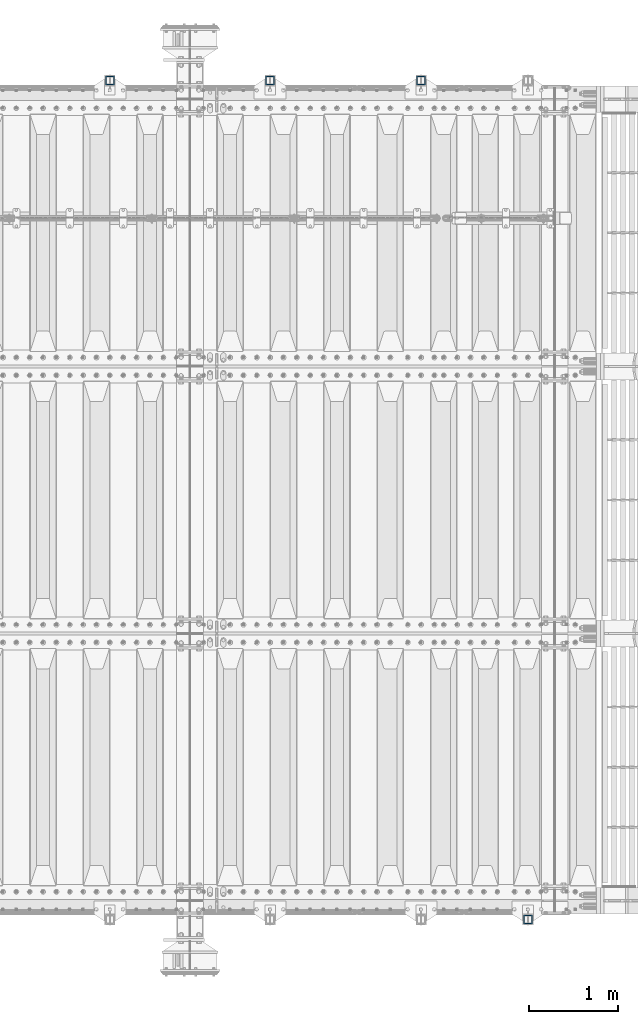
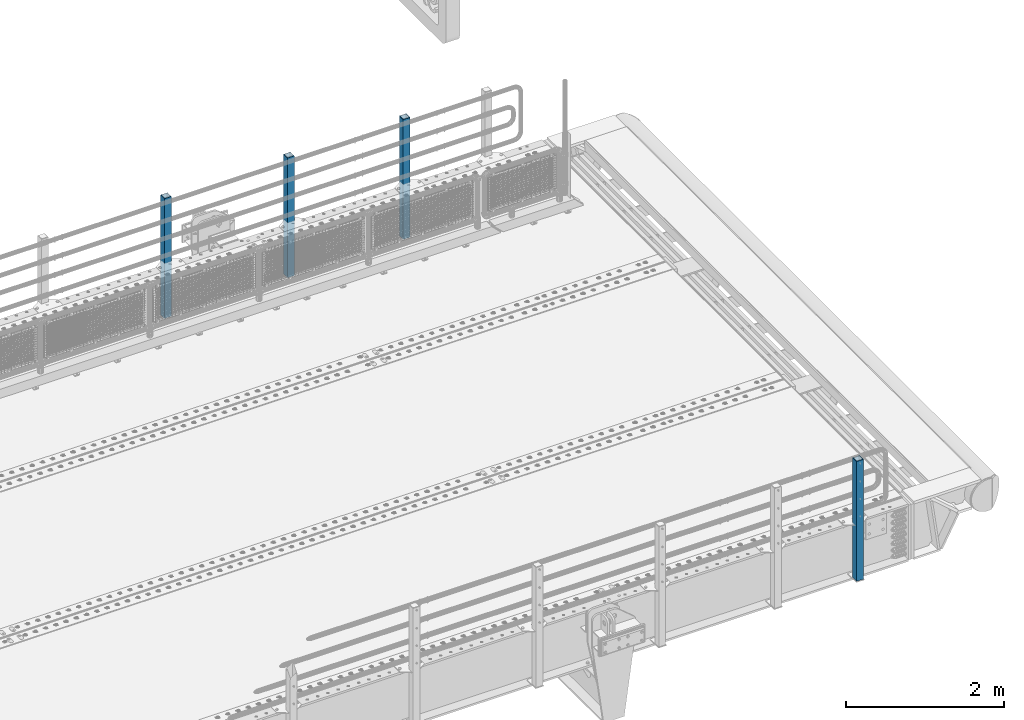
# One storey, part 64 of 247: 4 columns.
"""IFC2X3 building model written with IfcOpenShell, lengths in millimetres."""

from ifc_helpers import new_model, si_unit, frame, origin_with_axes, place, context, subcontext, project, spatial, faceted_brep, material, type_object, element, save


model = new_model("IFC2X3")

# Units and contexts
model_context = context("Model", 3, precision=1e-05, world=origin_with_axes())
body_context = subcontext(model_context, "Body", "Model", "MODEL_VIEW")
ifc_project = project(units=[si_unit("LENGTHUNIT", "METRE", prefix="MILLI"), si_unit("AREAUNIT", "SQUARE_METRE"), si_unit("VOLUMEUNIT", "CUBIC_METRE"), si_unit("MASSUNIT", "GRAM", prefix="KILO"), si_unit("TIMEUNIT", "SECOND"), si_unit("PLANEANGLEUNIT", "RADIAN"), si_unit("SOLIDANGLEUNIT", "STERADIAN"), si_unit("THERMODYNAMICTEMPERATUREUNIT", "DEGREE_CELSIUS"), si_unit("LUMINOUSINTENSITYUNIT", "LUMEN")], contexts=[model_context])

# Site, building, storey
site_placement = place(None, origin_with_axes())
site = spatial("IfcSite", under=ifc_project, at=site_placement, CompositionType="ELEMENT")
building_placement = place(site_placement, origin_with_axes())
building = spatial("IfcBuilding", under=site, at=building_placement, Name="Standard", CompositionType="ELEMENT")
storey_placement = place(building_placement, origin_with_axes())
storey = spatial("IfcBuildingStorey", under=building, at=storey_placement, Name="Undefined", CompositionType="ELEMENT", Elevation=0.0)

# Columns
ifc_material = material()
column_type = type_object("IfcColumnType", PredefinedType="NOTDEFINED")
for number, where, z_axis, x_axis in (
    (1, (14845.0000000001, 9210.00000000021, -844.999999999998), (0.0, -0.999999999999548, -9.5100000000016e-07), (0.0, 0.0, 1.0)),
    (2, (13150.0000000001, 9210.00000000021, -844.999999999998), (0.0, -0.999999999999548, -9.5100000000016e-07), (0.0, 0.0, 1.0)),
    (3, (11350.0000000001, 9210.00000000021, -844.999999999998), (0.0, -0.999999999999548, -9.5100000000016e-07), (0.0, 0.0, 1.0)),
    (4, (16044.9999999999, -210.000000000206, -844.999999999998), (0.0, 1.0, 0.0), (0.0, 0.0, 1.0)),
):
    element("IfcColumn", number, at=place(storey_placement, frame(where, z_axis=z_axis, x_axis=x_axis)), inside=storey, type_object=column_type, material=ifc_material, context=body_context, shape_type="Brep", body=[
        faceted_brep([(0.0, 40.0, -40.0), (0.0, -40.0, -40.0), (1855.0, -40.0, -40.0), (1855.0, 40.0, -40.0), (0.0, -40.0, 40.0), (1855.0, -40.0, 40.0), (0.0, 40.0, 40.0), (1855.0, 40.0, 40.0), (0.0, 50.0, -50.0), (0.0, 50.0, 50.0), (1855.0, 50.0, 50.0), (1855.0, 50.0, -50.0), (0.0, -50.0, 50.0), (1855.0, -50.0, 50.0), (0.0, -50.0, -50.0), (1855.0, -50.0, -50.0)], [[[0, 1, 2, 3]], [[1, 4, 5, 2]], [[4, 6, 7, 5]], [[6, 0, 3, 7]], [[8, 9, 10, 11]], [[9, 12, 13, 10]], [[12, 14, 15, 13]], [[14, 8, 11, 15]], [[13, 15, 11, 10], [5, 7, 3, 2]], [[14, 12, 9, 8], [6, 4, 1, 0]]]),
    ])

save(model, "model.ifc")
